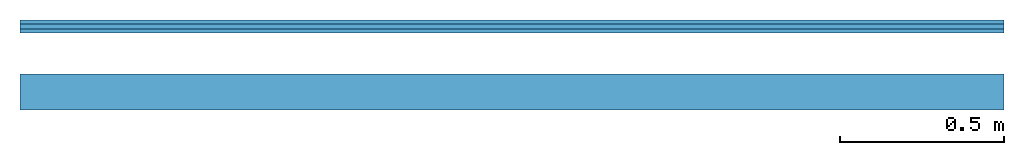
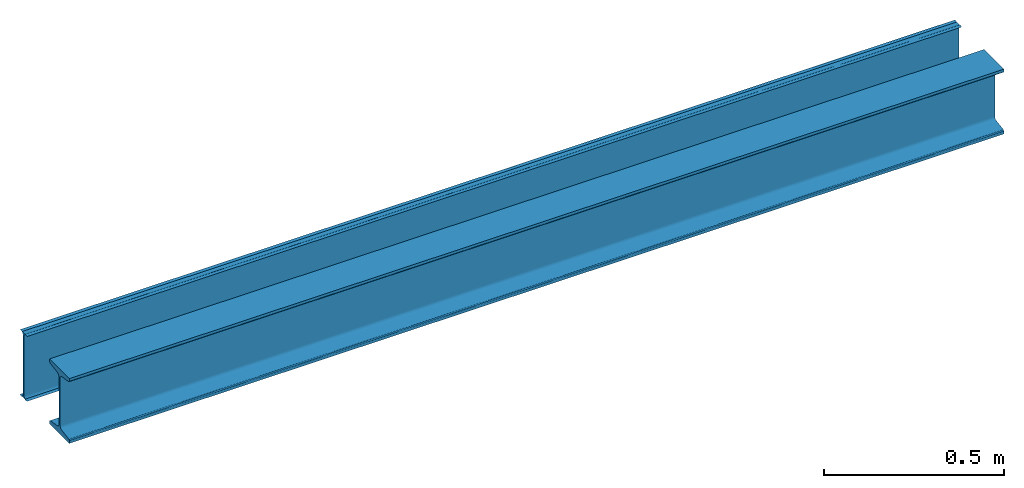
# One storey: 2 members.
"""IFC4 building model written with IfcOpenShell, lengths in millimetres."""

from ifc_helpers import new_model, si_unit, frame, frame_2d, origin_with_axes, place, context, subcontext, project, spatial, i_section, extrude, material, material_profile, profile_set, profile_usage, element, save


model = new_model("IFC4")

# Units and contexts
model_context = context("Model", 3, precision=1e-05, world=origin_with_axes())
plan_context = context("Plan", 2, precision=1e-05, world=frame_2d((0.0, 0.0, 0.0), x_axis=(1.0, 0.0, 0.0)))
body_context = subcontext(model_context, "Body", "Model", "MODEL_VIEW")
ifc_project = project(units=[si_unit("LENGTHUNIT", "METRE", prefix="MILLI"), si_unit("PLANEANGLEUNIT", "RADIAN"), si_unit("AREAUNIT", "SQUARE_METRE", prefix="MILLI"), si_unit("VOLUMEUNIT", "CUBIC_METRE", prefix="MILLI")], contexts=[model_context, plan_context])

# Site, building, storey
site_placement = place(None, origin_with_axes())
site = spatial("IfcSite", under=ifc_project, at=site_placement)
building_placement = place(site_placement, origin_with_axes())
building = spatial("IfcBuilding", under=site, at=building_placement, Name="Building")
storey_placement = place(building_placement, origin_with_axes())
storey = spatial("IfcBuildingStorey", under=building, at=storey_placement, Name="Storey")

# Members
ifc_material = material(Name="S345", Category="STEEL")
ifc_material_profile_1 = material_profile(ifc_material, i_section(OverallWidth=110.0, OverallDepth=220.0, WebThickness=7.5, FlangeThickness=12.3000001907349, FilletRadius=9.5, FlangeEdgeRadius=4.80000019073486, FlangeSlope=9.09000015258789))
ifc_profile_set_1 = profile_set([ifc_material_profile_1])
ifc_profile_usage_1 = profile_usage(ifc_profile_set_1)
member_1_placement = place(storey_placement, frame((0.0, 199.999988079071, 0.0), z_axis=(1.0, 1.62920741786365e-07, -4.01339264044509e-07), x_axis=(-1.62920684942947e-07, 1.0, 1.49011611938477e-07)))
element("IfcMember", 1, at=member_1_placement, inside=storey, material=ifc_profile_usage_1, Name="Member", PredefinedType="NOTDEFINED", context=body_context, shape_type="SweptSolid", body=[
    extrude(i_section(OverallWidth=110.0, OverallDepth=220.0, WebThickness=7.5, FlangeThickness=12.3000001907349, FilletRadius=9.5, FlangeEdgeRadius=4.80000019073486, FlangeSlope=9.09000015258789), origin_with_axes(), (0.0, 0.0, 1.0), 3000.00000000028),
])
ifc_material_profile_2 = material_profile(ifc_material, i_section(OverallWidth=110.0, OverallDepth=220.0, WebThickness=7.5, FlangeThickness=12.3, FilletRadius=9.5, FlangeEdgeRadius=4.8, FlangeSlope=0.158655262186401))
ifc_profile_set_2 = profile_set([ifc_material_profile_2])
ifc_profile_usage_2 = profile_usage(ifc_profile_set_2)
member_2_placement = place(storey_placement, frame((0.0, 0.0, 0.0), z_axis=(1.0, 1.62920699153801e-07, -1.62920684942947e-07), x_axis=(-1.62920684942947e-07, 1.0, 1.19209275339927e-07)))
element("IfcMember", 2, at=member_2_placement, inside=storey, material=ifc_profile_usage_2, Name="Member", PredefinedType="NOTDEFINED", context=body_context, shape_type="SweptSolid", body=[
    extrude(i_section(OverallWidth=110.0, OverallDepth=220.0, WebThickness=7.5, FlangeThickness=12.3, FilletRadius=9.5, FlangeEdgeRadius=4.8, FlangeSlope=0.158655262186401), origin_with_axes(), (0.0, 0.0, 1.0), 3000.00000000008),
])

save(model, "model.ifc")
